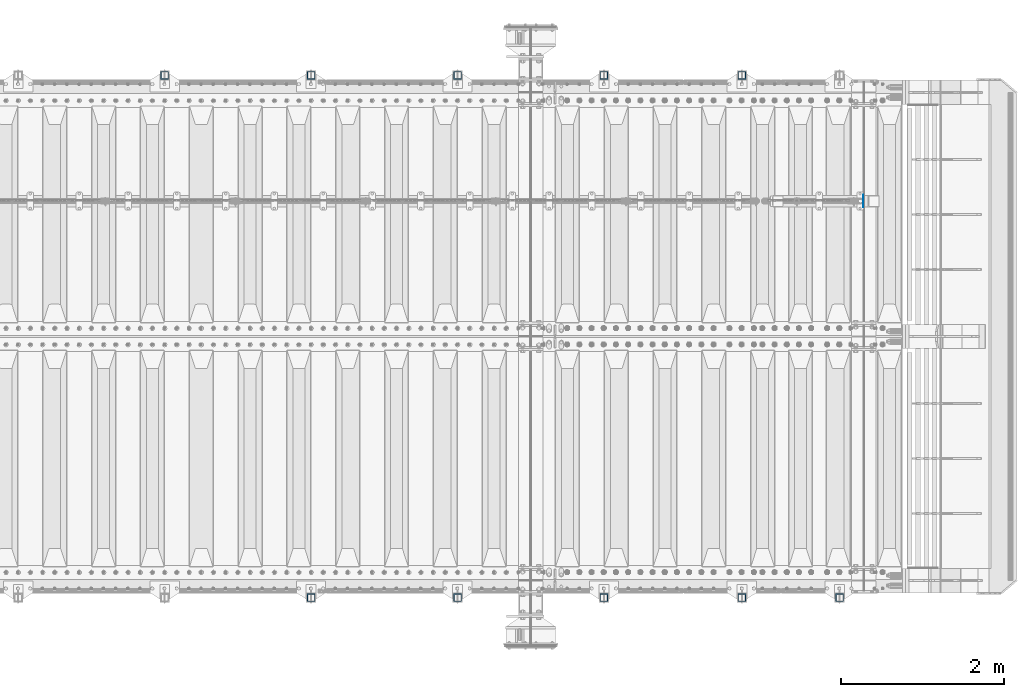
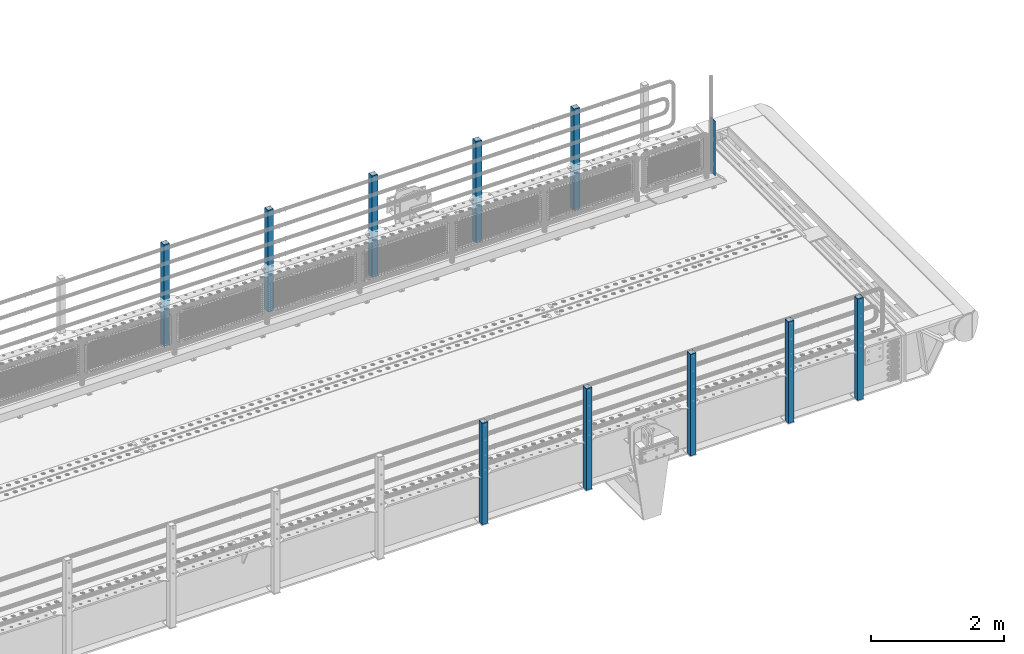
# One storey, part 51 of 208: 11 columns.
"""IFC2X3 building model written with IfcOpenShell, lengths in millimetres."""

from ifc_helpers import new_model, si_unit, frame, origin_with_axes, place, context, subcontext, project, spatial, faceted_brep, material, type_object, element, save


model = new_model("IFC2X3")

# Units and contexts
model_context = context("Model", 3, precision=1e-05, world=origin_with_axes())
body_context = subcontext(model_context, "Body", "Model", "MODEL_VIEW")
ifc_project = project(units=[si_unit("LENGTHUNIT", "METRE", prefix="MILLI"), si_unit("AREAUNIT", "SQUARE_METRE"), si_unit("VOLUMEUNIT", "CUBIC_METRE"), si_unit("MASSUNIT", "GRAM", prefix="KILO"), si_unit("TIMEUNIT", "SECOND"), si_unit("PLANEANGLEUNIT", "RADIAN"), si_unit("SOLIDANGLEUNIT", "STERADIAN"), si_unit("THERMODYNAMICTEMPERATUREUNIT", "DEGREE_CELSIUS"), si_unit("LUMINOUSINTENSITYUNIT", "LUMEN")], contexts=[model_context])

# Site, building, storey
site_placement = place(None, origin_with_axes())
site = spatial("IfcSite", under=ifc_project, at=site_placement, CompositionType="ELEMENT")
building_placement = place(site_placement, origin_with_axes())
building = spatial("IfcBuilding", under=site, at=building_placement, Name="Standard", CompositionType="ELEMENT")
storey_placement = place(building_placement, origin_with_axes())
storey = spatial("IfcBuildingStorey", under=building, at=storey_placement, Name="Undefined", CompositionType="ELEMENT", Elevation=0.0)

# Columns
ifc_material_1 = material(Name="Misc_Undefined")
column_type_1 = type_object("IfcColumnType", PredefinedType="NOTDEFINED")
column_placement = place(storey_placement, frame((-26112.5, 4664.5, 200.0), z_axis=(0.0, 1.0, 0.0), x_axis=(0.0, 0.0, 1.0)))
element("IfcColumn", 1, at=column_placement, inside=storey, type_object=column_type_1, material=ifc_material_1, context=body_context, shape_type="Brep", body=[
    faceted_brep([(0.0, 1.5, -75.0), (0.0, 1.5, 75.0), (1000.0, 1.5, 75.0), (1000.0, 1.5, -75.0), (0.0, -1.5, 75.0), (1000.0, -1.5, 75.0), (0.0, -1.5, -75.0), (1000.0, -1.5, -75.0)], [[[0, 1, 2, 3]], [[1, 4, 5, 2]], [[4, 6, 7, 5]], [[6, 0, 3, 7]], [[5, 7, 3, 2]], [[6, 4, 1, 0]]]),
])
ifc_material_2 = material()
column_type_2 = type_object("IfcColumnType", PredefinedType="NOTDEFINED")
for number, where, z_axis, x_axis in (
    (2, (-27604.9999999999, 6210.00000000021, -844.999999999998), (0.0, -1.0, 0.0), (0.0, 0.0, 1.0)),
    (3, (-29299.9999999999, 6210.00000000021, -844.999999999998), (0.0, -1.0, 0.0), (0.0, 0.0, 1.0)),
    (4, (-31099.9999999999, 6210.00000000021, -844.999999999998), (0.0, -1.0, 0.0), (0.0, 0.0, 1.0)),
    (5, (-32899.9999999999, 6210.00000000021, -844.999999999998), (0.0, -1.0, 0.0), (0.0, 0.0, 1.0)),
    (6, (-34699.9999999999, 6210.00000000021, -844.999999999998), (0.0, -1.0, 0.0), (0.0, 0.0, 1.0)),
    (7, (-26405.0000000001, -210.000000000206, -844.999999999998), (0.0, 1.0, 0.0), (0.0, 0.0, 1.0)),
    (8, (-27605.0000000001, -210.000000000206, -844.999999999998), (0.0, 1.0, 0.0), (0.0, 0.0, 1.0)),
    (9, (-29300.0000000001, -210.000000000206, -844.999999999998), (0.0, 1.0, 0.0), (0.0, 0.0, 1.0)),
    (10, (-31100.0000000001, -210.000000000206, -844.999999999998), (0.0, 1.0, 0.0), (0.0, 0.0, 1.0)),
    (11, (-32900.0000000001, -210.000000000206, -844.999999999998), (0.0, 1.0, 0.0), (0.0, 0.0, 1.0)),
):
    element("IfcColumn", number, at=place(storey_placement, frame(where, z_axis=z_axis, x_axis=x_axis)), inside=storey, type_object=column_type_2, material=ifc_material_2, context=body_context, shape_type="Brep", body=[
        faceted_brep([(0.0, 40.0, -40.0), (0.0, -40.0, -40.0), (1855.0, -40.0, -40.0), (1855.0, 40.0, -40.0), (0.0, -40.0, 40.0), (1855.0, -40.0, 40.0), (0.0, 40.0, 40.0), (1855.0, 40.0, 40.0), (0.0, 50.0, -50.0), (0.0, 50.0, 50.0), (1855.0, 50.0, 50.0), (1855.0, 50.0, -50.0), (0.0, -50.0, 50.0), (1855.0, -50.0, 50.0), (0.0, -50.0, -50.0), (1855.0, -50.0, -50.0)], [[[0, 1, 2, 3]], [[1, 4, 5, 2]], [[4, 6, 7, 5]], [[6, 0, 3, 7]], [[8, 9, 10, 11]], [[9, 12, 13, 10]], [[12, 14, 15, 13]], [[14, 8, 11, 15]], [[13, 15, 11, 10], [5, 7, 3, 2]], [[14, 12, 9, 8], [6, 4, 1, 0]]]),
    ])

save(model, "model.ifc")
